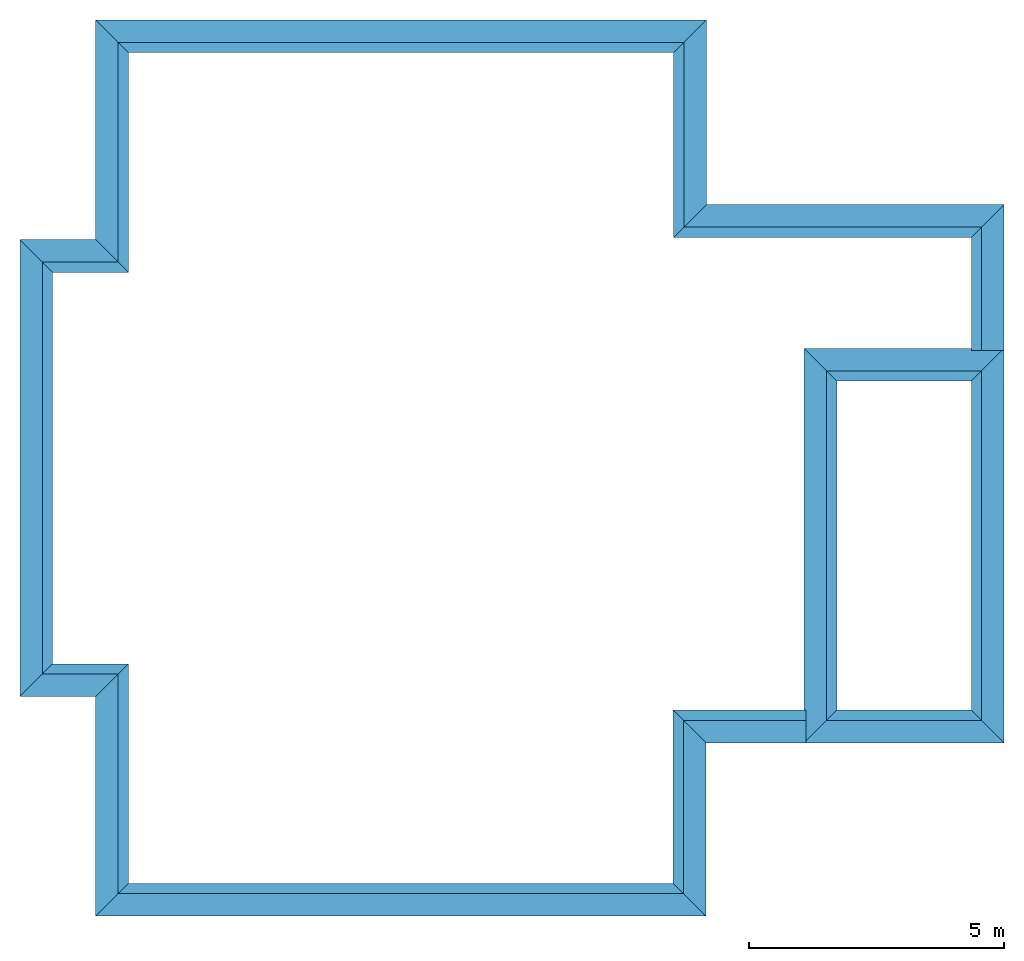
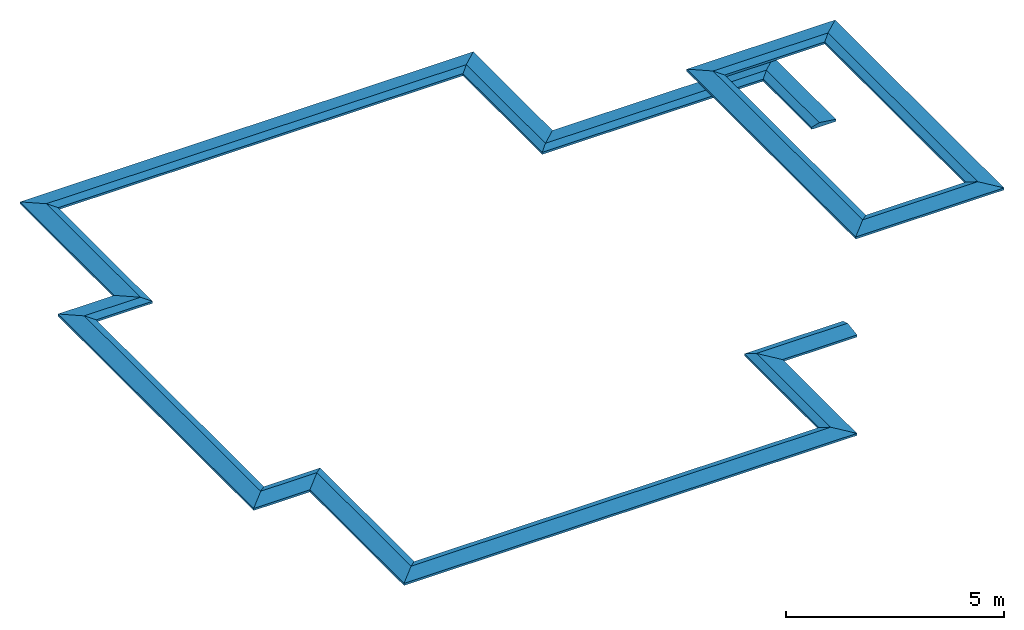
# One storey: 16 beams.
"""IFC2X3 building model written with IfcOpenShell, lengths in millimetres."""

from ifc_helpers import new_model, entity, si_unit, converted_unit, derived_unit, direction, frame, origin, place, context, subcontext, project, spatial, polyline, outline, extrude, clip, halfspace, material, type_object, element, save


model = new_model("IFC2X3")

# Units and contexts
model_context = context("Model", 3, precision=0.01, world=origin(), true_north=direction((6.12303176911189e-17, 1.0)))
body_context = subcontext(model_context, "Body", "Model", "MODEL_VIEW")
ifc_project = project(units=[si_unit("LENGTHUNIT", "METRE", prefix="MILLI"), si_unit("AREAUNIT", "SQUARE_METRE"), si_unit("VOLUMEUNIT", "CUBIC_METRE"), converted_unit("PLANEANGLEUNIT", "DEGREE", entity("IfcRatioMeasure", 0.0174532925199433), si_unit("PLANEANGLEUNIT", "RADIAN"), dimensions=[0, 0, 0, 0, 0, 0, 0]), si_unit("MASSUNIT", "GRAM", prefix="KILO"), derived_unit("MASSDENSITYUNIT", [(si_unit("MASSUNIT", "GRAM", prefix="KILO"), 1), (si_unit("LENGTHUNIT", "METRE"), -3)]), si_unit("TIMEUNIT", "SECOND"), si_unit("FREQUENCYUNIT", "HERTZ"), si_unit("THERMODYNAMICTEMPERATUREUNIT", "DEGREE_CELSIUS"), derived_unit("THERMALTRANSMITTANCEUNIT", [(si_unit("MASSUNIT", "GRAM", prefix="KILO"), 1), (si_unit("THERMODYNAMICTEMPERATUREUNIT", "KELVIN"), -1), (si_unit("TIMEUNIT", "SECOND"), -3)]), derived_unit("VOLUMETRICFLOWRATEUNIT", [(si_unit("LENGTHUNIT", "METRE"), 3), (si_unit("TIMEUNIT", "SECOND"), -1)]), si_unit("ELECTRICCURRENTUNIT", "AMPERE"), si_unit("ELECTRICVOLTAGEUNIT", "VOLT"), si_unit("POWERUNIT", "WATT"), si_unit("FORCEUNIT", "NEWTON", prefix="KILO"), si_unit("ILLUMINANCEUNIT", "LUX"), si_unit("LUMINOUSFLUXUNIT", "LUMEN"), si_unit("LUMINOUSINTENSITYUNIT", "CANDELA"), derived_unit("USERDEFINED", [(si_unit("MASSUNIT", "GRAM", prefix="KILO"), -1), (si_unit("LENGTHUNIT", "METRE"), -2), (si_unit("TIMEUNIT", "SECOND"), 3), (si_unit("LUMINOUSFLUXUNIT", "LUMEN"), 1)]), derived_unit("LINEARVELOCITYUNIT", [(si_unit("LENGTHUNIT", "METRE"), 1), (si_unit("TIMEUNIT", "SECOND"), -1)]), si_unit("PRESSUREUNIT", "PASCAL"), derived_unit("USERDEFINED", [(si_unit("LENGTHUNIT", "METRE"), -2), (si_unit("MASSUNIT", "GRAM", prefix="KILO"), 1), (si_unit("TIMEUNIT", "SECOND"), -2)])], contexts=[model_context])

# Site, building, storey
site_placement = place(None, origin())
site = spatial("IfcSite", under=ifc_project, at=site_placement, CompositionType="ELEMENT")
building_placement = place(site_placement, origin())
building = spatial("IfcBuilding", under=site, at=building_placement, CompositionType="ELEMENT")
storey_placement = place(building_placement, frame((0.0, 0.0, 16000.0)))
storey = spatial("IfcBuildingStorey", under=building, at=storey_placement, Name="04 Roof", CompositionType="ELEMENT", Elevation=16000.0)

# Beams
ifc_material = material(Name="08")
beam_type = type_object("IfcBeamType", PredefinedType="BEAM")
beam_1_placement = place(storey_placement, frame((34783.4900708518, -63705.8241905964, 1200.0), z_axis=(0.0, 0.0, 1.0), x_axis=(-1.0, 0.0, 0.0)))
element("IfcBeam", 1, at=beam_1_placement, inside=storey, type_object=beam_type, material=ifc_material, context=body_context, shape_type="Clipping", body=[
    clip(clip(extrude(outline(polyline([(-36.3636363636865, -330.909090909095), (23.6363636363128, -330.909090909095), (23.6363636363143, -320.909090909089), (13.6363636363144, -320.909090909088), (23.6363636363157, -310.909090909091), (23.6363636364045, 289.090909090911), (13.6363636364061, 299.09090909091), (23.6363636364038, 299.090909090909), (23.6363636364053, 309.090909090906), (-36.3636363635919, 309.090909090915), (-96.3636363636223, 109.090909090926), (-36.3636363636865, -330.909090909095)])), frame((-40.0, 290.909090909075, 23.6363636363606), z_axis=(1.0, 0.0, 0.0), x_axis=(0.0, 0.0, -1.0)), (0.0, 0.0, 1.0), 6479.99999999999), halfspace(frame((5800.0, -40.0, 0.0), z_axis=(0.707106781186546, -0.707106781186549, 0.0), x_axis=(-0.707106781186549, -0.707106781186546, 0.0)), False)), halfspace(frame((600.0, 600.0, 0.0), z_axis=(-0.707106781186546, 0.707106781186549, 0.0), x_axis=(-0.707106781186549, -0.707106781186546, 0.0)), False)),
])
beam_2_placement = place(storey_placement, frame((28943.4900708518, -60081.23958514, 1200.0), z_axis=(0.0, 0.0, 1.0), x_axis=(-1.0, 0.0, 0.0)))
element("IfcBeam", 2, at=beam_2_placement, inside=storey, type_object=beam_type, material=ifc_material, context=body_context, shape_type="Clipping", body=[
    clip(clip(extrude(outline(polyline([(-36.3636363637343, -330.909090909082), (23.6363636362651, -330.909090909082), (23.636363636268, -320.909090909084), (13.6363636362681, -320.909090909072), (23.6363636362708, -310.909090909077), (23.6363636364463, 289.090909090925), (13.6363636364471, 299.090909090925), (23.636363636447, 299.090909090922), (23.6363636364499, 309.09090909092), (-36.3636363635516, 309.090909090938), (-96.3636363636087, 109.090909090957), (-36.3636363637343, -330.909090909082)])), frame((-40.0, 290.909090909066, 23.6363636363606), z_axis=(1.0, 0.0, 0.0), x_axis=(0.0, 0.0, -1.0)), (0.0, 0.0, 1.0), 11980.0), halfspace(frame((11300.0, 600.0, 0.0), z_axis=(0.707106781186541, 0.707106781186554, 0.0), x_axis=(-0.707106781186554, 0.707106781186541, 0.0)), False)), halfspace(frame((600.0, 600.0, 0.0), z_axis=(-0.707106781186544, 0.707106781186551, 0.0), x_axis=(-0.707106781186551, -0.707106781186544, 0.0)), False)),
])
beam_3_placement = place(storey_placement, frame((28943.4900708518, -63705.8241905964, 1200.0), z_axis=(0.0, 0.0, 1.0), x_axis=(0.0, 1.0, 0.0)))
element("IfcBeam", 3, at=beam_3_placement, inside=storey, type_object=beam_type, material=ifc_material, context=body_context, shape_type="Clipping", body=[
    clip(clip(extrude(outline(polyline([(-36.3636363636344, -330.909090909092), (23.6363636363585, -330.909090909092), (23.6363636363563, -320.909090909094), (13.6363636363586, -320.909090909094), (23.6363636363585, -310.909090909097), (23.6363636363585, 289.090909090906), (13.6363636363564, 299.090909090908), (23.6363636363563, 299.090909090908), (23.6363636363541, 309.090909090905), (-36.3636363636452, 309.090909090905), (-96.3636363636446, 109.090909090912), (-36.3636363636344, -330.909090909092)])), frame((-600.0, 290.909090909082, 23.6363636363563), z_axis=(1.0, 0.0, 0.0), x_axis=(0.0, 0.0, -1.0)), (0.0, 0.0, 1.0), 4264.58460545638), halfspace(frame((3024.5846054564, 600.0, 0.0), z_axis=(0.707106781186555, 0.70710678118654, 0.0), x_axis=(0.70710678118654, -0.707106781186555, 0.0)), False)), halfspace(frame((40.0, -40.0, 0.0), z_axis=(-0.707106781186555, -0.70710678118654, 0.0), x_axis=(0.70710678118654, -0.707106781186555, 0.0)), False)),
])
beam_4_placement = place(storey_placement, frame((34783.4900708518, -66525.8241905964, 1200.0), z_axis=(0.0, 0.0, 1.0), x_axis=(0.0, 1.0, 0.0)))
element("IfcBeam", 4, at=beam_4_placement, inside=storey, type_object=beam_type, material=ifc_material, context=body_context, shape_type="Clipping", body=[
    clip(extrude(outline(polyline([(-36.3636363636366, -330.909090909092), (23.6363636363585, -330.909090909092), (23.6363636363585, -320.909090909094), (13.6363636363586, -320.909090909094), (23.6363636363585, -310.909090909092), (23.6363636363606, 289.090909090906), (13.6363636363607, 299.090909090908), (23.6363636363585, 299.090909090908), (23.6363636363585, 309.090909090905), (-36.3636363636387, 309.090909090905), (-96.3636363636403, 109.090909090908), (-36.3636363636366, -330.909090909092)])), frame((0.0, 290.909090909083, 23.6363636363585), z_axis=(1.0, 0.0, 0.0), x_axis=(0.0, 0.0, -1.0)), (0.0, 0.0, 1.0), 2860.0), halfspace(frame((2220.0, 600.0, 0.0), z_axis=(0.707106781186553, 0.707106781186542, 0.0), x_axis=(0.707106781186542, -0.707106781186553, 0.0)), False)),
])
beam_5_placement = place(storey_placement, frame((28933.4900708518, -77581.2395851399, 1200.0), z_axis=(0.0, 0.0, 1.0), x_axis=(0.0, 1.0, 0.0)))
element("IfcBeam", 5, at=beam_5_placement, inside=storey, type_object=beam_type, material=ifc_material, context=body_context, shape_type="Clipping", body=[
    clip(clip(extrude(outline(polyline([(-36.3636363636387, -330.909090909079), (23.6363636363563, -330.909090909079), (23.6363636363563, -320.909090909081), (13.6363636363564, -320.909090909081), (23.6363636363563, -310.909090909084), (23.6363636363585, 289.090909090919), (13.6363636363564, 299.090909090916), (23.6363636363585, 299.090909090921), (23.6363636363585, 309.090909090918), (-36.3636363636409, 309.090909090918), (-96.3636363636446, 109.090909090916), (-36.3636363636387, -330.909090909079)])), frame((-40.0, 290.909090909074, 23.6363636363563), z_axis=(1.0, 0.0, 0.0), x_axis=(0.0, 0.0, -1.0)), (0.0, 0.0, 1.0), 4040.41539454359), halfspace(frame((600.0, 600.0, 0.0), z_axis=(-0.707106781186551, 0.707106781186544, 0.0), x_axis=(-0.707106781186544, -0.707106781186551, 0.0)), False)), halfspace(frame((3360.41539454361, -40.0, 0.0), z_axis=(0.707106781186551, -0.707106781186544, 0.0), x_axis=(-0.707106781186544, -0.707106781186551, 0.0)), False)),
])
beam_6_placement = place(storey_placement, frame((28933.4900708518, -74180.8241905963, 1200.0)))
element("IfcBeam", 6, at=beam_6_placement, inside=storey, type_object=beam_type, material=ifc_material, context=body_context, shape_type="Clipping", body=[
    clip(extrude(outline(polyline([(-36.3636363636409, -330.909090909092), (23.6363636363585, -330.909090909092), (23.6363636363585, -320.909090909086), (13.6363636363586, -320.909090909086), (23.6363636363585, -310.909090909088), (23.6363636363606, 289.090909090914), (13.6363636363607, 299.090909090912), (23.6363636363585, 299.090909090912), (23.6363636363585, 309.09090909091), (-36.3636363636387, 309.09090909091), (-96.3636363636403, 109.090909090912), (-36.3636363636409, -330.909090909092)])), frame((-600.0, 290.909090909084, 23.6363636363585), z_axis=(1.0, 0.0, 0.0), x_axis=(0.0, 0.0, -1.0)), (0.0, 0.0, 1.0), 2610.00000000001), halfspace(frame((40.0, -40.0, 0.0), z_axis=(-0.707106781186541, -0.707106781186554, 0.0), x_axis=(0.707106781186554, -0.707106781186541, 0.0)), False)),
])
beam_7_placement = place(storey_placement, frame((17043.4900708518, -77581.2395851399, 1200.0)))
element("IfcBeam", 7, at=beam_7_placement, inside=storey, type_object=beam_type, material=ifc_material, context=body_context, shape_type="Clipping", body=[
    clip(clip(extrude(outline(polyline([(-36.363636363541, -330.909090909103), (23.6363636364583, -330.909090909103), (23.6363636364555, -320.909090909105), (13.6363636364556, -320.909090909099), (23.6363636364547, -310.909090909098), (23.6363636362815, 289.090909090904), (13.6363636362744, 299.090909090899), (23.6363636362764, 299.090909090902), (23.6363636362735, 309.090909090908), (-36.363636363728, 309.090909090882), (-96.3636363636674, 109.090909090867), (-36.363636363541, -330.909090909103)])), frame((-40.0, 290.909090909093, 23.6363636363628), z_axis=(1.0, 0.0, 0.0), x_axis=(0.0, 0.0, -1.0)), (0.0, 0.0, 1.0), 11970.0), halfspace(frame((600.0, 600.0, 0.0), z_axis=(-0.707106781186546, 0.707106781186549, 0.0), x_axis=(0.707106781186549, 0.707106781186546, 0.0)), False)), halfspace(frame((11290.0, 600.0, 0.0), z_axis=(0.707106781186541, 0.707106781186554, 0.0), x_axis=(0.707106781186554, -0.707106781186541, 0.0)), False)),
])
beam_8_placement = place(storey_placement, frame((15558.4900708518, -73271.2395851399, 1200.0)))
element("IfcBeam", 8, at=beam_8_placement, inside=storey, type_object=beam_type, material=ifc_material, context=body_context, shape_type="Clipping", body=[
    clip(clip(extrude(outline(polyline([(-36.3636363636431, -330.909090909083), (23.6363636363585, -330.909090909083), (23.6363636363585, -320.909090909086), (13.6363636363586, -320.909090909077), (23.6363636363585, -310.909090909079), (23.6363636363606, 289.090909090923), (13.6363636363586, 299.090909090921), (23.6363636363563, 299.090909090921), (23.6363636363585, 309.090909090918), (-36.3636363636409, 309.090909090918), (-96.3636363636424, 109.090909090912), (-36.3636363636431, -330.909090909083)])), frame((-40.0, 290.909090909075, 23.6363636363563), z_axis=(1.0, 0.0, 0.0), x_axis=(0.0, 0.0, -1.0)), (0.0, 0.0, 1.0), 2124.99999999993), halfspace(frame((600.0, 600.0, 0.0), z_axis=(-0.707106781186546, 0.707106781186549, 0.0), x_axis=(0.707106781186549, 0.707106781186546, 0.0)), False)), halfspace(frame((1445.0, -40.0, 0.0), z_axis=(0.707106781186546, -0.707106781186549, 0.0), x_axis=(0.707106781186549, 0.707106781186546, 0.0)), False)),
])
beam_9_placement = place(storey_placement, frame((17043.4900708518, -73271.2395851399, 1200.0), z_axis=(0.0, 0.0, 1.0), x_axis=(0.0, -1.0, 0.0)))
element("IfcBeam", 9, at=beam_9_placement, inside=storey, type_object=beam_type, material=ifc_material, context=body_context, shape_type="Clipping", body=[
    clip(clip(extrude(outline(polyline([(-36.3636363636366, -330.909090909088), (23.6363636363541, -330.909090909088), (23.6363636363541, -320.909090909086), (13.6363636363564, -320.909090909088), (23.6363636363563, -310.909090909086), (23.6363636363563, 289.090909090914), (13.6363636363521, 299.090909090914), (23.636363636352, 299.090909090912), (23.636363636352, 309.090909090914), (-36.3636363636474, 309.090909090912), (-96.3636363636467, 109.090909090914), (-36.3636363636366, -330.909090909088)])), frame((-600.0, 290.909090909081, 23.6363636363541), z_axis=(1.0, 0.0, 0.0), x_axis=(0.0, 0.0, -1.0)), (0.0, 0.0, 1.0), 4950.00000000003), halfspace(frame((40.0, -40.0, 0.0), z_axis=(-0.707106781186554, -0.707106781186541, 0.0), x_axis=(-0.707106781186541, 0.707106781186554, 0.0)), False)), halfspace(frame((3710.0, 600.0, 0.0), z_axis=(0.707106781186554, 0.707106781186541, 0.0), x_axis=(-0.707106781186541, 0.707106781186554, 0.0)), False)),
])
beam_10_placement = place(storey_placement, frame((15558.4900708518, -64391.2395851399, 1200.0), z_axis=(0.0, 0.0, 1.0), x_axis=(0.0, -1.0, 0.0)))
element("IfcBeam", 10, at=beam_10_placement, inside=storey, type_object=beam_type, material=ifc_material, context=body_context, shape_type="Clipping", body=[
    clip(clip(extrude(outline(polyline([(-36.3636363636366, -330.909090909092), (23.6363636363455, -330.909090909092), (23.6363636363433, -320.909090909092), (13.6363636363456, -320.909090909092), (23.6363636363455, -310.90909090909), (23.6363636363455, 289.09090909091), (13.6363636363456, 299.09090909091), (23.6363636363455, 299.090909090908), (23.6363636363455, 309.090909090908), (-36.3636363636539, 309.090909090908), (-96.3636363636554, 109.09090909091), (-36.3636363636366, -330.909090909092)])), frame((-40.0, 290.909090909087, 23.6363636363433), z_axis=(1.0, 0.0, 0.0), x_axis=(0.0, 0.0, -1.0)), (0.0, 0.0, 1.0), 8959.99999999997), halfspace(frame((8280.0, 600.0, 0.0), z_axis=(0.707106781186554, 0.707106781186541, 0.0), x_axis=(-0.707106781186541, 0.707106781186554, 0.0)), False)), halfspace(frame((600.0, 600.0, 0.0), z_axis=(-0.707106781186548, 0.707106781186547, 0.0), x_axis=(0.707106781186547, 0.707106781186548, 0.0)), False)),
])
beam_11_placement = place(storey_placement, frame((17043.4900708518, -64391.2395851399, 1200.0), z_axis=(0.0, 0.0, 1.0), x_axis=(-1.0, 0.0, 0.0)))
element("IfcBeam", 11, at=beam_11_placement, inside=storey, type_object=beam_type, material=ifc_material, context=body_context, shape_type="Clipping", body=[
    clip(clip(extrude(outline(polyline([(-36.3636363636409, -330.909090909092), (23.6363636363628, -330.909090909092), (23.6363636363628, -320.909090909094), (13.6363636363629, -320.909090909086), (23.636363636365, -310.909090909088), (23.6363636363671, 289.090909090914), (13.6363636363651, 299.090909090912), (23.636363636365, 299.090909090912), (23.6363636363628, 309.09090909091), (-36.3636363636366, 309.09090909091), (-96.3636363636359, 109.090909090903), (-36.3636363636409, -330.909090909092)])), frame((-600.0, 290.909090909084, 23.6363636363628), z_axis=(1.0, 0.0, 0.0), x_axis=(0.0, 0.0, -1.0)), (0.0, 0.0, 1.0), 2125.00000000005), halfspace(frame((885.0, 600.0, 0.0), z_axis=(0.707106781186541, 0.707106781186554, 0.0), x_axis=(-0.707106781186554, 0.707106781186541, 0.0)), False)), halfspace(frame((40.0, -40.0, 0.0), z_axis=(-0.707106781186541, -0.707106781186554, 0.0), x_axis=(-0.707106781186554, 0.707106781186541, 0.0)), False)),
])
beam_12_placement = place(storey_placement, frame((17043.4900708518, -60081.23958514, 1200.0), z_axis=(0.0, 0.0, 1.0), x_axis=(0.0, -1.0, 0.0)))
element("IfcBeam", 12, at=beam_12_placement, inside=storey, type_object=beam_type, material=ifc_material, context=body_context, shape_type="Clipping", body=[
    clip(clip(extrude(outline(polyline([(-36.3636363636344, -330.909090909088), (23.6363636363563, -330.909090909088), (23.6363636363563, -320.909090909086), (13.6363636363586, -320.909090909088), (23.6363636363585, -310.909090909086), (23.6363636363585, 289.090909090914), (13.6363636363586, 299.090909090914), (23.6363636363585, 299.090909090912), (23.6363636363585, 309.090909090914), (-36.3636363636409, 309.090909090912), (-96.3636363636424, 109.090909090914), (-36.3636363636344, -330.909090909088)])), frame((-40.0, 290.909090909081, 23.6363636363563), z_axis=(1.0, 0.0, 0.0), x_axis=(0.0, 0.0, -1.0)), (0.0, 0.0, 1.0), 4949.99999999996), halfspace(frame((4270.0, -40.0, 0.0), z_axis=(0.707106781186548, -0.707106781186547, 0.0), x_axis=(0.707106781186547, 0.707106781186548, 0.0)), False)), halfspace(frame((600.0, 600.0, 0.0), z_axis=(-0.707106781186548, 0.707106781186547, 0.0), x_axis=(0.707106781186547, 0.707106781186548, 0.0)), False)),
])
beam_13_placement = place(storey_placement, frame((34783.4900708518, -74180.8241905963, 3950.0), z_axis=(0.0, 0.0, 1.0), x_axis=(0.0, 1.0, 0.0)))
element("IfcBeam", 13, at=beam_13_placement, inside=storey, type_object=beam_type, material=ifc_material, context=body_context, shape_type="Clipping", body=[
    clip(clip(extrude(outline(polyline([(-36.3636363636387, -330.909090909083), (23.6363636363476, -330.909090909083), (23.6363636363476, -320.909090909086), (13.6363636363499, -320.909090909086), (23.6363636363476, -310.909090909088), (23.6363636363476, 289.090909090914), (13.6363636363499, 299.090909090912), (23.636363636352, 299.090909090916), (23.6363636363476, 309.090909090914), (-36.3636363636474, 309.090909090914), (-96.3636363636511, 109.090909090916), (-36.3636363636387, -330.909090909083)])), frame((-40.0, 290.90909090908, 23.6363636363476), z_axis=(1.0, 0.0, 0.0), x_axis=(0.0, 0.0, -1.0)), (0.0, 0.0, 1.0), 7734.99999999999), halfspace(frame((600.0, 600.0, 0.0), z_axis=(-0.707106781186556, 0.707106781186539, 0.0), x_axis=(-0.707106781186539, -0.707106781186556, 0.0)), False)), halfspace(frame((7055.0, 600.0, 0.0), z_axis=(0.707106781186548, 0.707106781186547, 0.0), x_axis=(0.707106781186547, -0.707106781186548, 0.0)), False)),
])
beam_14_placement = place(storey_placement, frame((34783.4900708518, -66525.8241905963, 3950.0), z_axis=(0.0, 0.0, 1.0), x_axis=(-1.0, 0.0, 0.0)))
element("IfcBeam", 14, at=beam_14_placement, inside=storey, type_object=beam_type, material=ifc_material, context=body_context, shape_type="Clipping", body=[
    clip(clip(extrude(outline(polyline([(-36.3636363634476, -330.909090909122), (23.6363636365561, -330.909090909122), (23.6363636365503, -320.909090909124), (13.6363636365526, -320.909090909121), (23.6363636365445, -310.909090909118), (23.636363636198, 289.090909090885), (13.6363636361945, 299.090909090885), (23.6363636361966, 299.090909090891), (23.6363636361864, 309.090909090889), (-36.3636363638086, 309.090909090854), (-96.3636363636968, 109.090909090813), (-36.3636363634476, -330.909090909122)])), frame((-40.0, 290.909090909127, 23.636363636365), z_axis=(1.0, 0.0, 0.0), x_axis=(0.0, 0.0, -1.0)), (0.0, 0.0, 1.0), 3920.00000000002), halfspace(frame((3240.0, 600.0, 0.0), z_axis=(0.707106781186541, 0.707106781186554, 0.0), x_axis=(-0.707106781186554, 0.707106781186541, 0.0)), False)), halfspace(frame((600.0, 600.0, 0.0), z_axis=(-0.707106781186544, 0.707106781186551, 0.0), x_axis=(-0.707106781186551, -0.707106781186544, 0.0)), False)),
])
beam_15_placement = place(storey_placement, frame((30943.4900708518, -66525.8241905964, 3950.0), z_axis=(0.0, 0.0, 1.0), x_axis=(0.0, -1.0, 0.0)))
element("IfcBeam", 15, at=beam_15_placement, inside=storey, type_object=beam_type, material=ifc_material, context=body_context, shape_type="Clipping", body=[
    clip(clip(extrude(outline(polyline([(-36.3636363636387, -330.909090909083), (23.6363636363476, -330.909090909083), (23.6363636363476, -320.909090909086), (13.6363636363499, -320.909090909086), (23.6363636363476, -310.909090909088), (23.6363636363476, 289.090909090914), (13.6363636363499, 299.090909090912), (23.636363636352, 299.090909090916), (23.6363636363476, 309.090909090914), (-36.3636363636474, 309.090909090914), (-96.3636363636511, 109.090909090912), (-36.3636363636387, -330.909090909083)])), frame((-40.0, 290.909090909082, 23.6363636363476), z_axis=(1.0, 0.0, 0.0), x_axis=(0.0, 0.0, -1.0)), (0.0, 0.0, 1.0), 7735.0), halfspace(frame((7055.0, 600.0, 0.0), z_axis=(0.707106781186551, 0.707106781186544, 0.0), x_axis=(-0.707106781186544, 0.707106781186551, 0.0)), False)), halfspace(frame((600.0, 600.0, 0.0), z_axis=(-0.707106781186554, 0.707106781186541, 0.0), x_axis=(0.707106781186541, 0.707106781186554, 0.0)), False)),
])
beam_16_placement = place(storey_placement, frame((30943.4900708518, -74180.8241905964, 3950.0)))
element("IfcBeam", 16, at=beam_16_placement, inside=storey, type_object=beam_type, material=ifc_material, context=body_context, shape_type="Clipping", body=[
    clip(clip(extrude(outline(polyline([(-36.3636363633998, -330.909090909101), (23.6363636366038, -330.909090909101), (23.6363636365966, -320.909090909103), (13.6363636365989, -320.909090909102), (23.6363636365894, -310.909090909097), (23.6363636361563, 289.090909090905), (13.6363636361513, 299.090909090905), (23.6363636361534, 299.090909090912), (23.6363636361418, 309.090909090909), (-36.3636363638532, 309.090909090866), (-96.3636363637125, 109.090909090816), (-36.3636363633998, -330.909090909101)])), frame((-40.0, 290.909090909119, 23.636363636365), z_axis=(1.0, 0.0, 0.0), x_axis=(0.0, 0.0, -1.0)), (0.0, 0.0, 1.0), 3919.99999999999), halfspace(frame((600.0, 600.0, 0.0), z_axis=(-0.707106781186542, 0.707106781186553, 0.0), x_axis=(0.707106781186553, 0.707106781186542, 0.0)), False)), halfspace(frame((3240.0, 600.0, 0.0), z_axis=(0.707106781186543, 0.707106781186552, 0.0), x_axis=(0.707106781186552, -0.707106781186543, 0.0)), False)),
])

save(model, "model.ifc")
